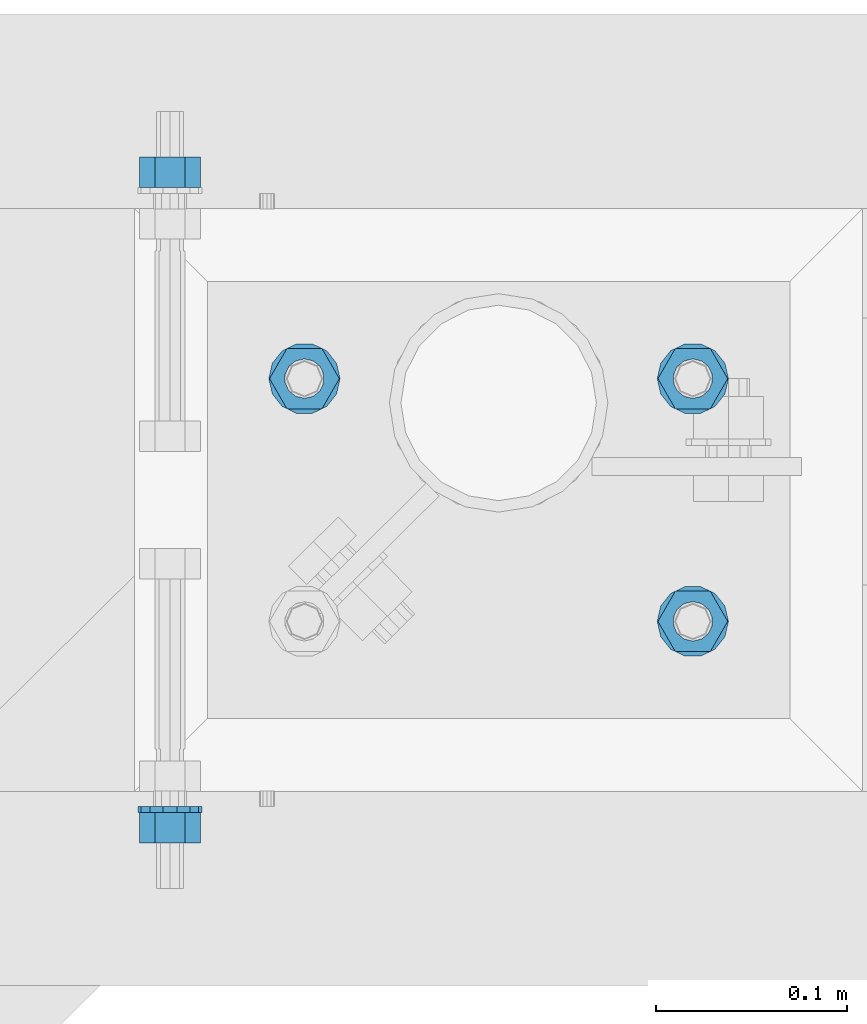
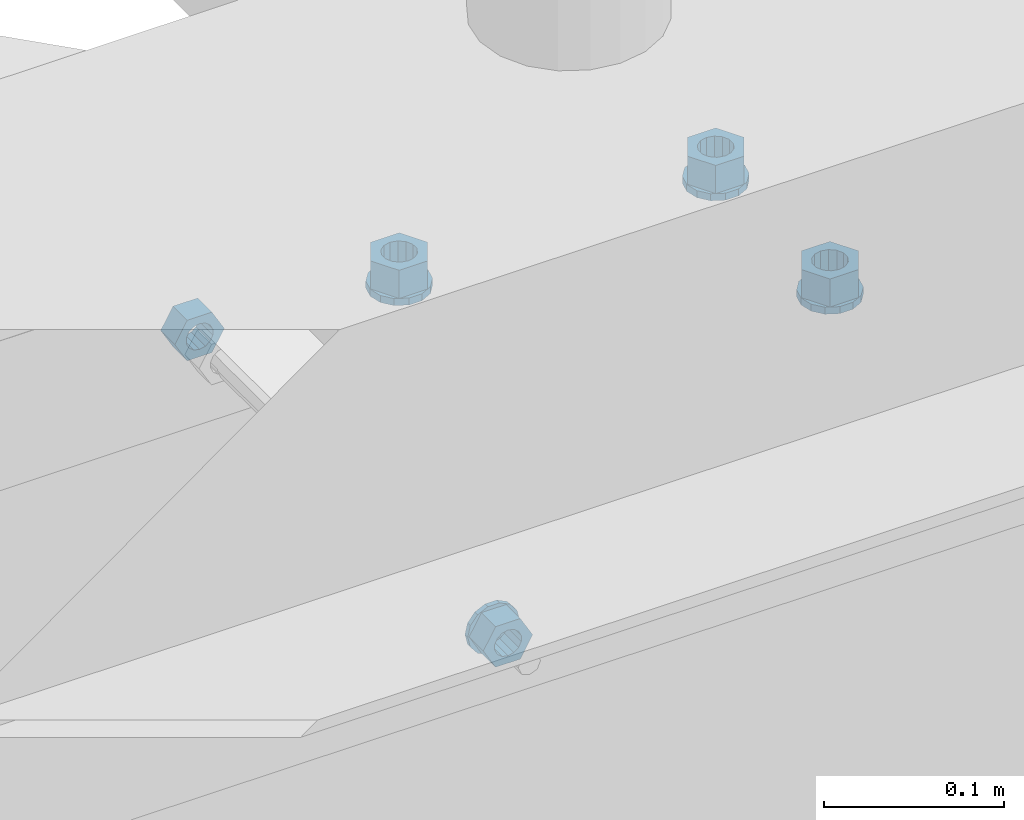
# One storey, part 607 of 975: 9 beams.
"""IFC2X3 building model written with IfcOpenShell, lengths in millimetres."""

from ifc_helpers import new_model, si_unit, frame, origin_with_axes, place, context, subcontext, project, spatial, faceted_brep, material, type_object, element, save


model = new_model("IFC2X3")

# Units and contexts
model_context = context("Model", 3, precision=1e-05, world=origin_with_axes())
body_context = subcontext(model_context, "Body", "Model", "MODEL_VIEW")
ifc_project = project(units=[si_unit("LENGTHUNIT", "METRE", prefix="MILLI"), si_unit("AREAUNIT", "SQUARE_METRE"), si_unit("VOLUMEUNIT", "CUBIC_METRE"), si_unit("MASSUNIT", "GRAM", prefix="KILO"), si_unit("TIMEUNIT", "SECOND"), si_unit("PLANEANGLEUNIT", "RADIAN"), si_unit("SOLIDANGLEUNIT", "STERADIAN"), si_unit("THERMODYNAMICTEMPERATUREUNIT", "DEGREE_CELSIUS"), si_unit("LUMINOUSINTENSITYUNIT", "LUMEN")], contexts=[model_context])

# Site, building, storey
site_placement = place(None, origin_with_axes())
site = spatial("IfcSite", under=ifc_project, at=site_placement, CompositionType="ELEMENT")
building_placement = place(site_placement, origin_with_axes())
building = spatial("IfcBuilding", under=site, at=building_placement, Name="Undefined", CompositionType="ELEMENT")
storey_placement = place(building_placement, origin_with_axes())
storey = spatial("IfcBuildingStorey", under=building, at=storey_placement, Name="Undefined", CompositionType="ELEMENT", Elevation=0.0)

# Beams
ifc_material = material(Name="STEEL/A36")
beam_type_1 = type_object("IfcBeamType", Name="5/8_HEAVY_HEX_NUT", PredefinedType="NOTDEFINED")
beam_1_placement = place(storey_placement, frame((7244.82086460171, 20775.6125, 3886.2), z_axis=(0.0, 0.0, 1.0), x_axis=(0.0, -1.0, 0.0)))
element("IfcBeam", 1, at=beam_1_placement, inside=storey, type_object=beam_type_1, material=ifc_material, Name="NUT", ObjectType="5/8_HEAVY_HEX_NUT", context=body_context, shape_type="Brep", body=[
    faceted_brep([(-1.09139364212751e-11, -15.8800001144436, -2.72848410531878e-12), (1.45519152283669e-11, -7.94000005722046, -13.7500000000036), (15.8750000000146, -7.94000005722137, -13.7500000000045), (15.8749999999891, -15.8800001144446, -2.72848410531878e-12), (2.91038304567337e-11, 7.94000005722319, -13.7500000000027), (15.8750000000291, 7.94000005722319, -13.7500000000027), (2.18278728425503e-11, 15.8800001144436, 9.09494701772928e-13), (15.8750000000218, 15.8800001144427, 9.09494701772928e-13), (-7.27595761418343e-12, 7.94000005722046, 13.7500000000027), (15.8749999999927, 7.94000005722046, 13.7500000000027), (-2.18278728425503e-11, -7.94000005722228, 13.7500000000009), (15.8749999999782, -7.94000005722319, 13.7500000000009), (-7.27595761418343e-12, 0.0, 8.72999954223724), (0.0, 3.78780484388062, 7.86545780435881), (15.875, 3.78780484387971, 7.86545780435881), (15.8749999999927, -9.09494701772928e-13, 8.72999954223724), (7.27595761418343e-12, 6.82538848405238, 5.44306568481716), (15.8750000000073, 6.82538848405238, 5.44306568481716), (1.09139364212751e-11, 8.51112022706275, 1.94260765157742), (15.8750000000109, 8.51112022706093, 1.94260765157651), (1.45519152283669e-11, 8.51112022706184, -1.94260765157651), (15.8750000000146, 8.51112022706184, -1.94260765157651), (2.18278728425503e-11, 6.8253884840542, -5.44306568481716), (15.8750000000218, 6.82538848405238, -5.44306568481716), (1.81898940354586e-11, 3.78780484388153, -7.86545780435881), (15.8750000000182, 3.78780484388062, -7.86545780435881), (1.81898940354586e-11, 9.09494701772928e-13, -8.72999954223997), (15.8750000000182, 9.09494701772928e-13, -8.72999954223997), (1.09139364212751e-11, -3.78780484387971, -7.86545780436063), (15.8750000000109, -3.78780484388062, -7.86545780436063), (3.63797880709171e-12, -6.82538848405238, -5.44306568481807), (15.8750000000036, -6.82538848405329, -5.44306568481807), (0.0, -8.51112022706184, -1.94260765157833), (15.875, -8.51112022706184, -1.94260765157833), (-7.27595761418343e-12, -8.51112022706184, 1.9426076515756), (15.8749999999927, -8.51112022706275, 1.9426076515756), (-1.09139364212751e-11, -6.82538848405329, 5.44306568481534), (15.8749999999927, -6.8253884840542, 5.44306568481534), (-7.27595761418343e-12, -3.78780484388062, 7.8654578043579), (15.8749999999927, -3.78780484388153, 7.8654578043579)], [[[0, 1, 2, 3]], [[1, 4, 5, 2]], [[4, 6, 7, 5]], [[6, 8, 9, 7]], [[8, 10, 11, 9]], [[10, 0, 3, 11]], [[12, 13, 14, 15]], [[13, 16, 17, 14]], [[16, 18, 19, 17]], [[18, 20, 21, 19]], [[20, 22, 23, 21]], [[22, 24, 25, 23]], [[24, 26, 27, 25]], [[26, 28, 29, 27]], [[28, 30, 31, 29]], [[30, 32, 33, 31]], [[32, 34, 35, 33]], [[34, 36, 37, 35]], [[36, 38, 39, 37]], [[38, 12, 15, 39]], [[5, 7, 9, 11, 3, 2], [17, 19, 21, 23, 25, 27, 29, 31, 33, 35, 37, 39, 15, 14]], [[10, 8, 6, 4, 1, 0], [38, 36, 34, 32, 30, 28, 26, 24, 22, 20, 18, 16, 13, 12]]]),
])
beam_2_placement = place(storey_placement, frame((7244.82086460171, 20416.8375, 3886.2), z_axis=(0.0, 0.0, -1.0), x_axis=(0.0, 1.0, 0.0)))
element("IfcBeam", 2, at=beam_2_placement, inside=storey, type_object=beam_type_1, material=ifc_material, Name="NUT", ObjectType="5/8_HEAVY_HEX_NUT", context=body_context, shape_type="Brep", body=[
    faceted_brep([(-1.09139364212751e-11, -15.8800001144436, -2.72848410531878e-12), (1.45519152283669e-11, -7.94000005722046, -13.7500000000036), (15.8750000000146, -7.94000005722137, -13.7500000000045), (15.8749999999891, -15.8800001144446, -2.72848410531878e-12), (2.91038304567337e-11, 7.94000005722319, -13.7500000000027), (15.8750000000291, 7.94000005722319, -13.7500000000027), (2.18278728425503e-11, 15.8800001144436, 9.09494701772928e-13), (15.8750000000218, 15.8800001144427, 9.09494701772928e-13), (-7.27595761418343e-12, 7.94000005722046, 13.7500000000027), (15.8749999999927, 7.94000005722046, 13.7500000000027), (-2.18278728425503e-11, -7.94000005722228, 13.7500000000009), (15.8749999999782, -7.94000005722319, 13.7500000000009), (-7.27595761418343e-12, 0.0, 8.72999954223724), (0.0, 3.78780484388062, 7.86545780435881), (15.875, 3.78780484387971, 7.86545780435881), (15.8749999999927, -9.09494701772928e-13, 8.72999954223724), (7.27595761418343e-12, 6.82538848405238, 5.44306568481716), (15.8750000000073, 6.82538848405238, 5.44306568481716), (1.09139364212751e-11, 8.51112022706275, 1.94260765157742), (15.8750000000109, 8.51112022706093, 1.94260765157651), (1.45519152283669e-11, 8.51112022706184, -1.94260765157651), (15.8750000000146, 8.51112022706184, -1.94260765157651), (2.18278728425503e-11, 6.8253884840542, -5.44306568481716), (15.8750000000218, 6.82538848405238, -5.44306568481716), (1.81898940354586e-11, 3.78780484388153, -7.86545780435881), (15.8750000000182, 3.78780484388062, -7.86545780435881), (1.81898940354586e-11, 9.09494701772928e-13, -8.72999954223997), (15.8750000000182, 9.09494701772928e-13, -8.72999954223997), (1.09139364212751e-11, -3.78780484387971, -7.86545780436063), (15.8750000000109, -3.78780484388062, -7.86545780436063), (3.63797880709171e-12, -6.82538848405238, -5.44306568481807), (15.8750000000036, -6.82538848405329, -5.44306568481807), (0.0, -8.51112022706184, -1.94260765157833), (15.875, -8.51112022706184, -1.94260765157833), (-7.27595761418343e-12, -8.51112022706184, 1.9426076515756), (15.8749999999927, -8.51112022706275, 1.9426076515756), (-1.09139364212751e-11, -6.82538848405329, 5.44306568481534), (15.8749999999927, -6.8253884840542, 5.44306568481534), (-7.27595761418343e-12, -3.78780484388062, 7.8654578043579), (15.8749999999927, -3.78780484388153, 7.8654578043579)], [[[0, 1, 2, 3]], [[1, 4, 5, 2]], [[4, 6, 7, 5]], [[6, 8, 9, 7]], [[8, 10, 11, 9]], [[10, 0, 3, 11]], [[12, 13, 14, 15]], [[13, 16, 17, 14]], [[16, 18, 19, 17]], [[18, 20, 21, 19]], [[20, 22, 23, 21]], [[22, 24, 25, 23]], [[24, 26, 27, 25]], [[26, 28, 29, 27]], [[28, 30, 31, 29]], [[30, 32, 33, 31]], [[32, 34, 35, 33]], [[34, 36, 37, 35]], [[36, 38, 39, 37]], [[38, 12, 15, 39]], [[5, 7, 9, 11, 3, 2], [17, 19, 21, 23, 25, 27, 29, 31, 33, 35, 37, 39, 15, 14]], [[10, 8, 6, 4, 1, 0], [38, 36, 34, 32, 30, 28, 26, 24, 22, 20, 18, 16, 13, 12]]]),
])
beam_type_2 = type_object("IfcBeamType", Name="5/8_WASHER", PredefinedType="NOTDEFINED")
beam_3_placement = place(storey_placement, frame((7244.82086460174, 20432.7125, 3886.2), z_axis=(0.0, 0.0, -1.0), x_axis=(0.0, 1.0, 0.0)))
element("IfcBeam", 3, at=beam_3_placement, inside=storey, type_object=beam_type_2, material=ifc_material, Name="WASHER", ObjectType="5/8_WASHER", context=body_context, shape_type="Brep", body=[
    faceted_brep([(1.09139364212751e-11, -16.670000076293, -2.72848410531878e-12), (2.18278728425503e-11, -15.0191510966704, -7.23284196419536), (3.1750000000211, -15.0191510966711, -7.23284196419627), (3.17500000001019, -16.6700000762937, -1.81898940354586e-12), (2.91038304567337e-11, -10.3935750445523, -13.0331308723944), (3.17500000002838, -10.3935750445526, -13.0331308723953), (2.91038304567337e-11, -3.70942398602756, -16.2520483704566), (3.17500000002838, -3.70942398602779, -16.2520483704566), (2.5465851649642e-11, 3.70942398602961, -16.2520483704557), (3.17500000002474, 3.70942398602961, -16.2520483704566), (1.45519152283669e-11, 10.3935750445542, -13.0331308723935), (3.17500000001382, 10.3935750445537, -13.0331308723944), (0.0, 15.0191510966717, -7.23284196419354), (3.17499999999927, 15.0191510966713, -7.23284196419354), (-7.27595761418343e-12, 16.6700000762933, 0.0), (3.174999999992, 16.6700000762928, -9.09494701772928e-13), (-1.81898940354586e-11, 15.0191510966706, 7.23284196419354), (3.17499999998108, 15.0191510966704, 7.23284196419354), (-2.5465851649642e-11, 10.3935750445519, 13.0331308723926), (3.17499999997381, 10.3935750445517, 13.0331308723926), (-2.5465851649642e-11, 3.70942398602733, 16.2520483704538), (3.17499999997381, 3.7094239860271, 16.2520483704529), (-2.18278728425503e-11, -3.70942398602983, 16.2520483704529), (3.17499999997744, -3.70942398603006, 16.2520483704538), (-1.09139364212751e-11, -10.3935750445542, 13.0331308723908), (3.17499999998836, -10.3935750445544, 13.0331308723908), (0.0, -15.0191510966717, 7.23284196419172), (3.17499999999927, -15.019151096672, 7.23284196419081), (-7.27595761418343e-12, 0.0, 8.72999954223724), (0.0, 3.78780484388062, 7.86545780435881), (3.17499999998472, 3.78780484387903, 7.86545780435699), (3.17499999998836, -9.09494701772928e-13, 8.72999954223542), (7.27595761418343e-12, 6.82538848405238, 5.44306568481716), (3.17499999998836, 6.82538848405102, 5.44306568481534), (1.09139364212751e-11, 8.51112022706275, 1.94260765157742), (3.174999999992, 8.51112022705979, 1.94260765157651), (1.45519152283669e-11, 8.51112022706184, -1.94260765157651), (3.17499999999563, 8.51112022706025, -1.94260765157742), (2.18278728425503e-11, 6.8253884840542, -5.44306568481716), (3.17500000000655, 6.8253884840517, -5.44306568481807), (1.81898940354586e-11, 3.78780484388153, -7.86545780435881), (3.17500000001019, 3.78780484388017, -7.86545780435972), (1.81898940354586e-11, 9.09494701772928e-13, -8.72999954223997), (3.17500000001382, 6.82121026329696e-13, -8.72999954223997), (1.09139364212751e-11, -3.78780484387971, -7.86545780436063), (3.17500000001382, -3.78780484387994, -7.86545780436063), (3.63797880709171e-12, -6.82538848405238, -5.44306568481807), (3.17500000001019, -6.82538848405147, -5.44306568481898), (0.0, -8.51112022706184, -1.94260765157833), (3.17500000001019, -8.5111202270607, -1.94260765157924), (-7.27595761418343e-12, -8.51112022706184, 1.9426076515756), (3.17500000000291, -8.51112022706093, 1.94260765157469), (-1.09139364212751e-11, -6.82538848405329, 5.44306568481534), (3.17499999999563, -6.82538848405238, 5.44306568481534), (-7.27595761418343e-12, -3.78780484388062, 7.8654578043579), (3.174999999992, -3.78780484388085, 7.86545780435699)], [[[0, 1, 2, 3]], [[1, 4, 5, 2]], [[4, 6, 7, 5]], [[6, 8, 9, 7]], [[8, 10, 11, 9]], [[10, 12, 13, 11]], [[12, 14, 15, 13]], [[14, 16, 17, 15]], [[16, 18, 19, 17]], [[18, 20, 21, 19]], [[20, 22, 23, 21]], [[22, 24, 25, 23]], [[24, 26, 27, 25]], [[26, 0, 3, 27]], [[28, 29, 30, 31]], [[29, 32, 33, 30]], [[32, 34, 35, 33]], [[34, 36, 37, 35]], [[36, 38, 39, 37]], [[38, 40, 41, 39]], [[40, 42, 43, 41]], [[42, 44, 45, 43]], [[44, 46, 47, 45]], [[46, 48, 49, 47]], [[48, 50, 51, 49]], [[50, 52, 53, 51]], [[52, 54, 55, 53]], [[54, 28, 31, 55]], [[5, 7, 9, 11, 13, 15, 17, 19, 21, 23, 25, 27, 3, 2], [33, 35, 37, 39, 41, 43, 45, 47, 49, 51, 53, 55, 31, 30]], [[26, 24, 22, 20, 18, 16, 14, 12, 10, 8, 6, 4, 1, 0], [54, 52, 50, 48, 46, 44, 42, 40, 38, 36, 34, 32, 29, 28]]]),
])
beam_type_3 = type_object("IfcBeamType", Name="3/4_WASHER", PredefinedType="NOTDEFINED")
beam_4_placement = place(storey_placement, frame((7518.40000117523, 20659.7249986259, 3960.8125), z_axis=(0.0, -1.0, 0.0), x_axis=(0.0, 0.0, -1.0)))
element("IfcBeam", 4, at=beam_4_placement, inside=storey, type_object=beam_type_3, material=ifc_material, Name="WASHER", ObjectType="3/4_WASHER", context=body_context, shape_type="Brep", body=[
    faceted_brep([(0.0, -18.6499996185303, 0.0), (0.0, -16.8030690426876, -8.09193156902904), (4.76250000000073, -16.8030690426876, -8.09193156902904), (4.76250000000073, -18.6499996185303, 0.0), (0.0, -11.6280845668225, -14.5811568497838), (4.76250000000073, -11.6280845668225, -14.5811568497838), (0.0, -4.15001533340001, -18.1824051902857), (4.76250000000073, -4.15001533340001, -18.1824051902857), (0.0, 4.15001533340001, -18.1824051902857), (4.76250000000073, 4.15001533340001, -18.1824051902857), (0.0, 11.6280845668234, -14.5811568497838), (4.76250000000073, 11.6280845668234, -14.5811568497838), (0.0, 16.8030690426876, -8.09193156902904), (4.76250000000073, 16.8030690426876, -8.09193156902904), (0.0, 18.6499996185303, 0.0), (4.76250000000073, 18.6499996185303, 0.0), (0.0, 16.8030690426876, 8.09193156902904), (4.76250000000073, 16.8030690426876, 8.09193156902904), (0.0, 11.6280845668225, 14.5811568497838), (4.76250000000073, 11.6280845668225, 14.5811568497838), (0.0, 4.15001533340001, 18.1824051902857), (4.76250000000073, 4.15001533340001, 18.1824051902857), (0.0, -4.15001533340001, 18.1824051902857), (4.76250000000073, -4.15001533340001, 18.1824051902857), (0.0, -11.6280845668234, 14.5811568497838), (4.76250000000073, -11.6280845668234, 14.5811568497838), (0.0, -16.8030690426876, 8.09193156902904), (4.76250000000073, -16.8030690426876, 8.09193156902904), (0.0, 0.0, 10.3199996948242), (0.0, 4.47768005528269, 9.29799844179911), (4.76250000000073, 4.47768005528269, 9.29799844179911), (4.76250000000073, 0.0, 10.3199996948242), (0.0, 8.06850066047446, 6.43441456490817), (4.76250000000073, 8.06850066047446, 6.43441456490817), (0.0, 10.0612557561917, 2.29641597052117), (4.76250000000073, 10.0612557561917, 2.29641597052117), (0.0, 10.0612557561917, -2.29641597052117), (4.76250000000073, 10.0612557561917, -2.29641597052117), (0.0, 8.06850066047446, -6.43441456490814), (4.76250000000073, 8.06850066047446, -6.43441456490814), (0.0, 4.47768005528269, -9.29799844179908), (4.76250000000073, 4.47768005528269, -9.29799844179908), (0.0, 0.0, -10.3199996948242), (4.76250000000073, 0.0, -10.3199996948242), (0.0, -4.47768005528269, -9.29799844179911), (4.76250000000073, -4.47768005528269, -9.29799844179911), (0.0, -8.06850066047446, -6.43441456490817), (4.76250000000073, -8.06850066047446, -6.43441456490817), (0.0, -10.0612557561917, -2.29641597052117), (4.76250000000073, -10.0612557561917, -2.29641597052117), (0.0, -10.0612557561917, 2.29641597052117), (4.76250000000073, -10.0612557561917, 2.29641597052117), (0.0, -8.06850066047446, 6.43441456490814), (4.76250000000073, -8.06850066047446, 6.43441456490814), (0.0, -4.47768005528269, 9.29799844179908), (4.76250000000073, -4.47768005528269, 9.29799844179908)], [[[0, 1, 2, 3]], [[1, 4, 5, 2]], [[4, 6, 7, 5]], [[6, 8, 9, 7]], [[8, 10, 11, 9]], [[10, 12, 13, 11]], [[12, 14, 15, 13]], [[14, 16, 17, 15]], [[16, 18, 19, 17]], [[18, 20, 21, 19]], [[20, 22, 23, 21]], [[22, 24, 25, 23]], [[24, 26, 27, 25]], [[26, 0, 3, 27]], [[28, 29, 30, 31]], [[29, 32, 33, 30]], [[32, 34, 35, 33]], [[34, 36, 37, 35]], [[36, 38, 39, 37]], [[38, 40, 41, 39]], [[40, 42, 43, 41]], [[42, 44, 45, 43]], [[44, 46, 47, 45]], [[46, 48, 49, 47]], [[48, 50, 51, 49]], [[50, 52, 53, 51]], [[52, 54, 55, 53]], [[54, 28, 31, 55]], [[5, 7, 9, 11, 13, 15, 17, 19, 21, 23, 25, 27, 3, 2], [33, 35, 37, 39, 41, 43, 45, 47, 49, 51, 53, 55, 31, 30]], [[26, 24, 22, 20, 18, 16, 14, 12, 10, 8, 6, 4, 1, 0], [54, 52, 50, 48, 46, 44, 42, 40, 38, 36, 34, 32, 29, 28]]]),
])
beam_5_placement = place(storey_placement, frame((7315.20000117522, 20659.7249986259, 3960.8125), z_axis=(0.0, -1.0, 0.0), x_axis=(0.0, 0.0, -1.0)))
element("IfcBeam", 5, at=beam_5_placement, inside=storey, type_object=beam_type_3, material=ifc_material, Name="WASHER", ObjectType="3/4_WASHER", context=body_context, shape_type="Brep", body=[
    faceted_brep([(0.0, -18.6499996185303, 0.0), (0.0, -16.8030690426876, -8.09193156902904), (4.76250000000073, -16.8030690426876, -8.09193156902904), (4.76250000000073, -18.6499996185303, 0.0), (0.0, -11.6280845668225, -14.5811568497838), (4.76250000000073, -11.6280845668225, -14.5811568497838), (0.0, -4.15001533340001, -18.1824051902857), (4.76250000000073, -4.15001533340001, -18.1824051902857), (0.0, 4.15001533340001, -18.1824051902857), (4.76250000000073, 4.15001533340001, -18.1824051902857), (0.0, 11.6280845668234, -14.5811568497838), (4.76250000000073, 11.6280845668234, -14.5811568497838), (0.0, 16.8030690426876, -8.09193156902904), (4.76250000000073, 16.8030690426876, -8.09193156902904), (0.0, 18.6499996185303, 0.0), (4.76250000000073, 18.6499996185303, 0.0), (0.0, 16.8030690426876, 8.09193156902904), (4.76250000000073, 16.8030690426876, 8.09193156902904), (0.0, 11.6280845668225, 14.5811568497838), (4.76250000000073, 11.6280845668225, 14.5811568497838), (0.0, 4.15001533340001, 18.1824051902857), (4.76250000000073, 4.15001533340001, 18.1824051902857), (0.0, -4.15001533340001, 18.1824051902857), (4.76250000000073, -4.15001533340001, 18.1824051902857), (0.0, -11.6280845668234, 14.5811568497838), (4.76250000000073, -11.6280845668234, 14.5811568497838), (0.0, -16.8030690426876, 8.09193156902904), (4.76250000000073, -16.8030690426876, 8.09193156902904), (0.0, 0.0, 10.3199996948242), (0.0, 4.47768005528269, 9.29799844179911), (4.76250000000073, 4.47768005528269, 9.29799844179911), (4.76250000000073, 0.0, 10.3199996948242), (0.0, 8.06850066047446, 6.43441456490817), (4.76250000000073, 8.06850066047446, 6.43441456490817), (0.0, 10.0612557561917, 2.29641597052117), (4.76250000000073, 10.0612557561917, 2.29641597052117), (0.0, 10.0612557561917, -2.29641597052117), (4.76250000000073, 10.0612557561917, -2.29641597052117), (0.0, 8.06850066047446, -6.43441456490814), (4.76250000000073, 8.06850066047446, -6.43441456490814), (0.0, 4.47768005528269, -9.29799844179908), (4.76250000000073, 4.47768005528269, -9.29799844179908), (0.0, 0.0, -10.3199996948242), (4.76250000000073, 0.0, -10.3199996948242), (0.0, -4.47768005528269, -9.29799844179911), (4.76250000000073, -4.47768005528269, -9.29799844179911), (0.0, -8.06850066047446, -6.43441456490817), (4.76250000000073, -8.06850066047446, -6.43441456490817), (0.0, -10.0612557561917, -2.29641597052117), (4.76250000000073, -10.0612557561917, -2.29641597052117), (0.0, -10.0612557561917, 2.29641597052117), (4.76250000000073, -10.0612557561917, 2.29641597052117), (0.0, -8.06850066047446, 6.43441456490814), (4.76250000000073, -8.06850066047446, 6.43441456490814), (0.0, -4.47768005528269, 9.29799844179908), (4.76250000000073, -4.47768005528269, 9.29799844179908)], [[[0, 1, 2, 3]], [[1, 4, 5, 2]], [[4, 6, 7, 5]], [[6, 8, 9, 7]], [[8, 10, 11, 9]], [[10, 12, 13, 11]], [[12, 14, 15, 13]], [[14, 16, 17, 15]], [[16, 18, 19, 17]], [[18, 20, 21, 19]], [[20, 22, 23, 21]], [[22, 24, 25, 23]], [[24, 26, 27, 25]], [[26, 0, 3, 27]], [[28, 29, 30, 31]], [[29, 32, 33, 30]], [[32, 34, 35, 33]], [[34, 36, 37, 35]], [[36, 38, 39, 37]], [[38, 40, 41, 39]], [[40, 42, 43, 41]], [[42, 44, 45, 43]], [[44, 46, 47, 45]], [[46, 48, 49, 47]], [[48, 50, 51, 49]], [[50, 52, 53, 51]], [[52, 54, 55, 53]], [[54, 28, 31, 55]], [[5, 7, 9, 11, 13, 15, 17, 19, 21, 23, 25, 27, 3, 2], [33, 35, 37, 39, 41, 43, 45, 47, 49, 51, 53, 55, 31, 30]], [[26, 24, 22, 20, 18, 16, 14, 12, 10, 8, 6, 4, 1, 0], [54, 52, 50, 48, 46, 44, 42, 40, 38, 36, 34, 32, 29, 28]]]),
])
beam_6_placement = place(storey_placement, frame((7518.40000117523, 20532.7249986259, 3960.8125), z_axis=(0.0, -1.0, 0.0), x_axis=(0.0, 0.0, -1.0)))
element("IfcBeam", 6, at=beam_6_placement, inside=storey, type_object=beam_type_3, material=ifc_material, Name="WASHER", ObjectType="3/4_WASHER", context=body_context, shape_type="Brep", body=[
    faceted_brep([(0.0, -18.6499996185303, 0.0), (0.0, -16.8030690426876, -8.09193156902904), (4.76250000000073, -16.8030690426876, -8.09193156902904), (4.76250000000073, -18.6499996185303, 0.0), (0.0, -11.6280845668225, -14.5811568497838), (4.76250000000073, -11.6280845668225, -14.5811568497838), (0.0, -4.15001533340001, -18.1824051902857), (4.76250000000073, -4.15001533340001, -18.1824051902857), (0.0, 4.15001533340001, -18.1824051902857), (4.76250000000073, 4.15001533340001, -18.1824051902857), (0.0, 11.6280845668234, -14.5811568497838), (4.76250000000073, 11.6280845668234, -14.5811568497838), (0.0, 16.8030690426876, -8.09193156902904), (4.76250000000073, 16.8030690426876, -8.09193156902904), (0.0, 18.6499996185303, 0.0), (4.76250000000073, 18.6499996185303, 0.0), (0.0, 16.8030690426876, 8.09193156902904), (4.76250000000073, 16.8030690426876, 8.09193156902904), (0.0, 11.6280845668225, 14.5811568497838), (4.76250000000073, 11.6280845668225, 14.5811568497838), (0.0, 4.15001533340001, 18.1824051902857), (4.76250000000073, 4.15001533340001, 18.1824051902857), (0.0, -4.15001533340001, 18.1824051902857), (4.76250000000073, -4.15001533340001, 18.1824051902857), (0.0, -11.6280845668234, 14.5811568497838), (4.76250000000073, -11.6280845668234, 14.5811568497838), (0.0, -16.8030690426876, 8.09193156902904), (4.76250000000073, -16.8030690426876, 8.09193156902904), (0.0, 0.0, 10.3199996948242), (0.0, 4.47768005528269, 9.29799844179911), (4.76250000000073, 4.47768005528269, 9.29799844179911), (4.76250000000073, 0.0, 10.3199996948242), (0.0, 8.06850066047446, 6.43441456490817), (4.76250000000073, 8.06850066047446, 6.43441456490817), (0.0, 10.0612557561917, 2.29641597052117), (4.76250000000073, 10.0612557561917, 2.29641597052117), (0.0, 10.0612557561917, -2.29641597052117), (4.76250000000073, 10.0612557561917, -2.29641597052117), (0.0, 8.06850066047446, -6.43441456490814), (4.76250000000073, 8.06850066047446, -6.43441456490814), (0.0, 4.47768005528269, -9.29799844179908), (4.76250000000073, 4.47768005528269, -9.29799844179908), (0.0, 0.0, -10.3199996948242), (4.76250000000073, 0.0, -10.3199996948242), (0.0, -4.47768005528269, -9.29799844179911), (4.76250000000073, -4.47768005528269, -9.29799844179911), (0.0, -8.06850066047446, -6.43441456490817), (4.76250000000073, -8.06850066047446, -6.43441456490817), (0.0, -10.0612557561917, -2.29641597052117), (4.76250000000073, -10.0612557561917, -2.29641597052117), (0.0, -10.0612557561917, 2.29641597052117), (4.76250000000073, -10.0612557561917, 2.29641597052117), (0.0, -8.06850066047446, 6.43441456490814), (4.76250000000073, -8.06850066047446, 6.43441456490814), (0.0, -4.47768005528269, 9.29799844179908), (4.76250000000073, -4.47768005528269, 9.29799844179908)], [[[0, 1, 2, 3]], [[1, 4, 5, 2]], [[4, 6, 7, 5]], [[6, 8, 9, 7]], [[8, 10, 11, 9]], [[10, 12, 13, 11]], [[12, 14, 15, 13]], [[14, 16, 17, 15]], [[16, 18, 19, 17]], [[18, 20, 21, 19]], [[20, 22, 23, 21]], [[22, 24, 25, 23]], [[24, 26, 27, 25]], [[26, 0, 3, 27]], [[28, 29, 30, 31]], [[29, 32, 33, 30]], [[32, 34, 35, 33]], [[34, 36, 37, 35]], [[36, 38, 39, 37]], [[38, 40, 41, 39]], [[40, 42, 43, 41]], [[42, 44, 45, 43]], [[44, 46, 47, 45]], [[46, 48, 49, 47]], [[48, 50, 51, 49]], [[50, 52, 53, 51]], [[52, 54, 55, 53]], [[54, 28, 31, 55]], [[5, 7, 9, 11, 13, 15, 17, 19, 21, 23, 25, 27, 3, 2], [33, 35, 37, 39, 41, 43, 45, 47, 49, 51, 53, 55, 31, 30]], [[26, 24, 22, 20, 18, 16, 14, 12, 10, 8, 6, 4, 1, 0], [54, 52, 50, 48, 46, 44, 42, 40, 38, 36, 34, 32, 29, 28]]]),
])
beam_type_4 = type_object("IfcBeamType", Name="3/4_HEAVY_HEX_NUT", PredefinedType="NOTDEFINED")
beam_7_placement = place(storey_placement, frame((7518.40000117523, 20659.7249986259, 3979.8625), z_axis=(0.0, -1.0, 0.0), x_axis=(0.0, 0.0, -1.0)))
element("IfcBeam", 7, at=beam_7_placement, inside=storey, type_object=beam_type_4, material=ifc_material, Name="NUT", ObjectType="3/4_HEAVY_HEX_NUT", context=body_context, shape_type="Brep", body=[
    faceted_brep([(0.0, -18.2600002288818, 0.0), (0.0, -9.13000011444092, -15.8100004196167), (19.0499999999993, -9.13000011444092, -15.8100004196167), (19.0499999999993, -18.2600002288818, 0.0), (0.0, 9.13000011444092, -15.8100004196167), (19.0499999999993, 9.13000011444092, -15.8100004196167), (0.0, 18.2600002288818, 0.0), (19.0499999999993, 18.2600002288818, 0.0), (0.0, 9.13000011444092, 15.8100004196167), (19.0499999999993, 9.13000011444092, 15.8100004196167), (0.0, -9.13000011444092, 15.8100004196167), (19.0499999999993, -9.13000011444092, 15.8100004196167), (0.0, 0.0, 10.3199996948242), (0.0, 4.47768005528269, 9.29799844179911), (19.0499999999993, 4.47768005528269, 9.29799844179911), (19.0499999999993, 0.0, 10.3199996948242), (0.0, 8.06850066047446, 6.43441456490817), (19.0499999999993, 8.06850066047446, 6.43441456490817), (0.0, 10.0612557561917, 2.29641597052117), (19.0499999999993, 10.0612557561917, 2.29641597052117), (0.0, 10.0612557561917, -2.29641597052117), (19.0499999999993, 10.0612557561917, -2.29641597052117), (0.0, 8.06850066047446, -6.43441456490814), (19.0499999999993, 8.06850066047446, -6.43441456490814), (0.0, 4.47768005528269, -9.29799844179908), (19.0499999999993, 4.47768005528269, -9.29799844179908), (0.0, 0.0, -10.3199996948242), (19.0499999999993, 0.0, -10.3199996948242), (0.0, -4.47768005528269, -9.29799844179911), (19.0499999999993, -4.47768005528269, -9.29799844179911), (0.0, -8.06850066047446, -6.43441456490817), (19.0499999999993, -8.06850066047446, -6.43441456490817), (0.0, -10.0612557561917, -2.29641597052117), (19.0499999999993, -10.0612557561917, -2.29641597052117), (0.0, -10.0612557561917, 2.29641597052117), (19.0499999999993, -10.0612557561917, 2.29641597052117), (0.0, -8.06850066047446, 6.43441456490814), (19.0499999999993, -8.06850066047446, 6.43441456490814), (0.0, -4.47768005528269, 9.29799844179908), (19.0499999999993, -4.47768005528269, 9.29799844179908)], [[[0, 1, 2, 3]], [[1, 4, 5, 2]], [[4, 6, 7, 5]], [[6, 8, 9, 7]], [[8, 10, 11, 9]], [[10, 0, 3, 11]], [[12, 13, 14, 15]], [[13, 16, 17, 14]], [[16, 18, 19, 17]], [[18, 20, 21, 19]], [[20, 22, 23, 21]], [[22, 24, 25, 23]], [[24, 26, 27, 25]], [[26, 28, 29, 27]], [[28, 30, 31, 29]], [[30, 32, 33, 31]], [[32, 34, 35, 33]], [[34, 36, 37, 35]], [[36, 38, 39, 37]], [[38, 12, 15, 39]], [[5, 7, 9, 11, 3, 2], [17, 19, 21, 23, 25, 27, 29, 31, 33, 35, 37, 39, 15, 14]], [[10, 8, 6, 4, 1, 0], [38, 36, 34, 32, 30, 28, 26, 24, 22, 20, 18, 16, 13, 12]]]),
])
beam_8_placement = place(storey_placement, frame((7315.20000117522, 20659.7249986259, 3979.8625), z_axis=(0.0, -1.0, 0.0), x_axis=(0.0, 0.0, -1.0)))
element("IfcBeam", 8, at=beam_8_placement, inside=storey, type_object=beam_type_4, material=ifc_material, Name="NUT", ObjectType="3/4_HEAVY_HEX_NUT", context=body_context, shape_type="Brep", body=[
    faceted_brep([(0.0, -18.2600002288818, 0.0), (0.0, -9.13000011444092, -15.8100004196167), (19.0499999999993, -9.13000011444092, -15.8100004196167), (19.0499999999993, -18.2600002288818, 0.0), (0.0, 9.13000011444092, -15.8100004196167), (19.0499999999993, 9.13000011444092, -15.8100004196167), (0.0, 18.2600002288818, 0.0), (19.0499999999993, 18.2600002288818, 0.0), (0.0, 9.13000011444092, 15.8100004196167), (19.0499999999993, 9.13000011444092, 15.8100004196167), (0.0, -9.13000011444092, 15.8100004196167), (19.0499999999993, -9.13000011444092, 15.8100004196167), (0.0, 0.0, 10.3199996948242), (0.0, 4.47768005528269, 9.29799844179911), (19.0499999999993, 4.47768005528269, 9.29799844179911), (19.0499999999993, 0.0, 10.3199996948242), (0.0, 8.06850066047446, 6.43441456490817), (19.0499999999993, 8.06850066047446, 6.43441456490817), (0.0, 10.0612557561917, 2.29641597052117), (19.0499999999993, 10.0612557561917, 2.29641597052117), (0.0, 10.0612557561917, -2.29641597052117), (19.0499999999993, 10.0612557561917, -2.29641597052117), (0.0, 8.06850066047446, -6.43441456490814), (19.0499999999993, 8.06850066047446, -6.43441456490814), (0.0, 4.47768005528269, -9.29799844179908), (19.0499999999993, 4.47768005528269, -9.29799844179908), (0.0, 0.0, -10.3199996948242), (19.0499999999993, 0.0, -10.3199996948242), (0.0, -4.47768005528269, -9.29799844179911), (19.0499999999993, -4.47768005528269, -9.29799844179911), (0.0, -8.06850066047446, -6.43441456490817), (19.0499999999993, -8.06850066047446, -6.43441456490817), (0.0, -10.0612557561917, -2.29641597052117), (19.0499999999993, -10.0612557561917, -2.29641597052117), (0.0, -10.0612557561917, 2.29641597052117), (19.0499999999993, -10.0612557561917, 2.29641597052117), (0.0, -8.06850066047446, 6.43441456490814), (19.0499999999993, -8.06850066047446, 6.43441456490814), (0.0, -4.47768005528269, 9.29799844179908), (19.0499999999993, -4.47768005528269, 9.29799844179908)], [[[0, 1, 2, 3]], [[1, 4, 5, 2]], [[4, 6, 7, 5]], [[6, 8, 9, 7]], [[8, 10, 11, 9]], [[10, 0, 3, 11]], [[12, 13, 14, 15]], [[13, 16, 17, 14]], [[16, 18, 19, 17]], [[18, 20, 21, 19]], [[20, 22, 23, 21]], [[22, 24, 25, 23]], [[24, 26, 27, 25]], [[26, 28, 29, 27]], [[28, 30, 31, 29]], [[30, 32, 33, 31]], [[32, 34, 35, 33]], [[34, 36, 37, 35]], [[36, 38, 39, 37]], [[38, 12, 15, 39]], [[5, 7, 9, 11, 3, 2], [17, 19, 21, 23, 25, 27, 29, 31, 33, 35, 37, 39, 15, 14]], [[10, 8, 6, 4, 1, 0], [38, 36, 34, 32, 30, 28, 26, 24, 22, 20, 18, 16, 13, 12]]]),
])
beam_9_placement = place(storey_placement, frame((7518.40000117523, 20532.7249986259, 3979.8625), z_axis=(0.0, -1.0, 0.0), x_axis=(0.0, 0.0, -1.0)))
element("IfcBeam", 9, at=beam_9_placement, inside=storey, type_object=beam_type_4, material=ifc_material, Name="NUT", ObjectType="3/4_HEAVY_HEX_NUT", context=body_context, shape_type="Brep", body=[
    faceted_brep([(0.0, -18.2600002288818, 0.0), (0.0, -9.13000011444092, -15.8100004196167), (19.0499999999993, -9.13000011444092, -15.8100004196167), (19.0499999999993, -18.2600002288818, 0.0), (0.0, 9.13000011444092, -15.8100004196167), (19.0499999999993, 9.13000011444092, -15.8100004196167), (0.0, 18.2600002288818, 0.0), (19.0499999999993, 18.2600002288818, 0.0), (0.0, 9.13000011444092, 15.8100004196167), (19.0499999999993, 9.13000011444092, 15.8100004196167), (0.0, -9.13000011444092, 15.8100004196167), (19.0499999999993, -9.13000011444092, 15.8100004196167), (0.0, 0.0, 10.3199996948242), (0.0, 4.47768005528269, 9.29799844179911), (19.0499999999993, 4.47768005528269, 9.29799844179911), (19.0499999999993, 0.0, 10.3199996948242), (0.0, 8.06850066047446, 6.43441456490817), (19.0499999999993, 8.06850066047446, 6.43441456490817), (0.0, 10.0612557561917, 2.29641597052117), (19.0499999999993, 10.0612557561917, 2.29641597052117), (0.0, 10.0612557561917, -2.29641597052117), (19.0499999999993, 10.0612557561917, -2.29641597052117), (0.0, 8.06850066047446, -6.43441456490814), (19.0499999999993, 8.06850066047446, -6.43441456490814), (0.0, 4.47768005528269, -9.29799844179908), (19.0499999999993, 4.47768005528269, -9.29799844179908), (0.0, 0.0, -10.3199996948242), (19.0499999999993, 0.0, -10.3199996948242), (0.0, -4.47768005528269, -9.29799844179911), (19.0499999999993, -4.47768005528269, -9.29799844179911), (0.0, -8.06850066047446, -6.43441456490817), (19.0499999999993, -8.06850066047446, -6.43441456490817), (0.0, -10.0612557561917, -2.29641597052117), (19.0499999999993, -10.0612557561917, -2.29641597052117), (0.0, -10.0612557561917, 2.29641597052117), (19.0499999999993, -10.0612557561917, 2.29641597052117), (0.0, -8.06850066047446, 6.43441456490814), (19.0499999999993, -8.06850066047446, 6.43441456490814), (0.0, -4.47768005528269, 9.29799844179908), (19.0499999999993, -4.47768005528269, 9.29799844179908)], [[[0, 1, 2, 3]], [[1, 4, 5, 2]], [[4, 6, 7, 5]], [[6, 8, 9, 7]], [[8, 10, 11, 9]], [[10, 0, 3, 11]], [[12, 13, 14, 15]], [[13, 16, 17, 14]], [[16, 18, 19, 17]], [[18, 20, 21, 19]], [[20, 22, 23, 21]], [[22, 24, 25, 23]], [[24, 26, 27, 25]], [[26, 28, 29, 27]], [[28, 30, 31, 29]], [[30, 32, 33, 31]], [[32, 34, 35, 33]], [[34, 36, 37, 35]], [[36, 38, 39, 37]], [[38, 12, 15, 39]], [[5, 7, 9, 11, 3, 2], [17, 19, 21, 23, 25, 27, 29, 31, 33, 35, 37, 39, 15, 14]], [[10, 8, 6, 4, 1, 0], [38, 36, 34, 32, 30, 28, 26, 24, 22, 20, 18, 16, 13, 12]]]),
])

save(model, "model.ifc")
